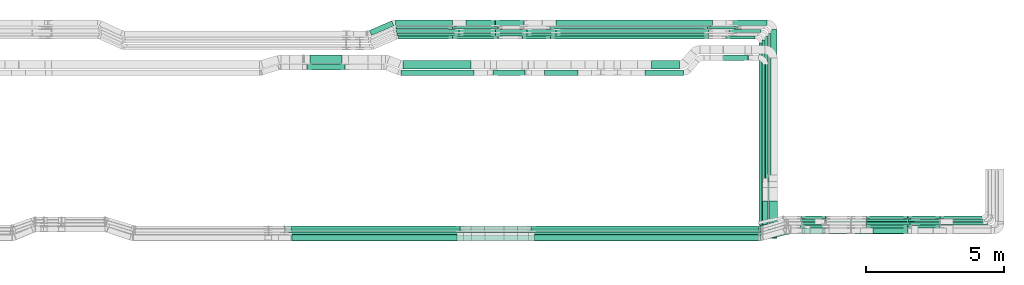
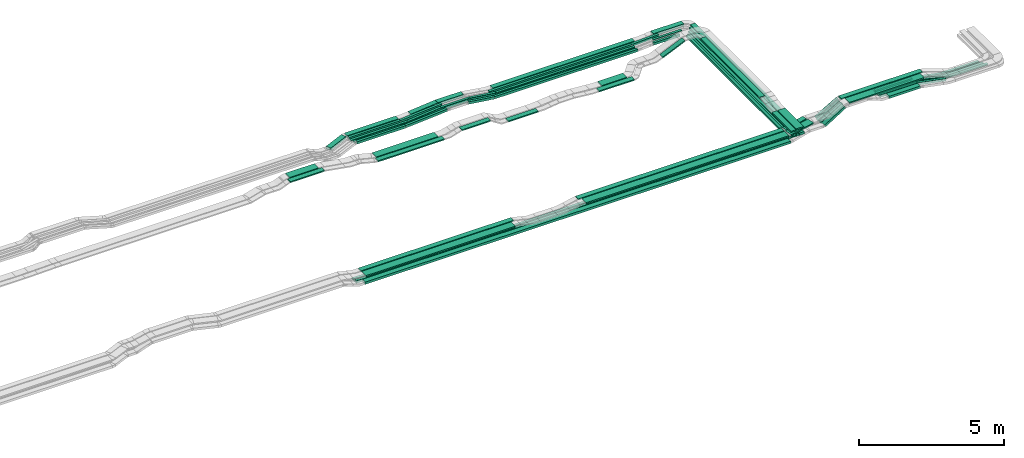
# One storey, part 2 of 28: 72 flow segments.
"""IFC2X3 building model written with IfcOpenShell, lengths in millimetres."""

from ifc_helpers import new_model, entity, si_unit, converted_unit, derived_unit, direction, frame, frame_2d, origin, origin_2d_with_axis, place, context, subcontext, project, spatial, rectangle, extrude, type_object, element, save


model = new_model("IFC2X3")

# Units and contexts
model_context = context("Model", 3, precision=0.01, world=origin(), true_north=direction((6.12303176911189e-17, 1.0)))
body_context = subcontext(model_context, "Body", "Model", "MODEL_VIEW")
ifc_project = project(units=[si_unit("LENGTHUNIT", "METRE", prefix="MILLI"), si_unit("AREAUNIT", "SQUARE_METRE"), si_unit("VOLUMEUNIT", "CUBIC_METRE"), converted_unit("PLANEANGLEUNIT", "DEGREE", entity("IfcRatioMeasure", 0.0174532925199433), si_unit("PLANEANGLEUNIT", "RADIAN"), dimensions=[0, 0, 0, 0, 0, 0, 0]), si_unit("MASSUNIT", "GRAM", prefix="KILO"), derived_unit("MASSDENSITYUNIT", [(si_unit("MASSUNIT", "GRAM", prefix="KILO"), 1), (si_unit("LENGTHUNIT", "METRE"), -3)]), derived_unit("MOMENTOFINERTIAUNIT", [(si_unit("LENGTHUNIT", "METRE"), 4)]), si_unit("TIMEUNIT", "SECOND"), si_unit("FREQUENCYUNIT", "HERTZ"), si_unit("THERMODYNAMICTEMPERATUREUNIT", "DEGREE_CELSIUS"), derived_unit("THERMALTRANSMITTANCEUNIT", [(si_unit("MASSUNIT", "GRAM", prefix="KILO"), 1), (si_unit("THERMODYNAMICTEMPERATUREUNIT", "KELVIN"), -1), (si_unit("TIMEUNIT", "SECOND"), -3)]), derived_unit("VOLUMETRICFLOWRATEUNIT", [(si_unit("LENGTHUNIT", "METRE"), 3), (si_unit("TIMEUNIT", "SECOND"), -1)]), derived_unit("MASSFLOWRATEUNIT", [(si_unit("MASSUNIT", "GRAM", prefix="KILO"), 1), (si_unit("TIMEUNIT", "SECOND"), -1)]), derived_unit("ROTATIONALFREQUENCYUNIT", [(si_unit("TIMEUNIT", "SECOND"), -1)]), si_unit("ELECTRICCURRENTUNIT", "AMPERE"), si_unit("ELECTRICVOLTAGEUNIT", "VOLT"), si_unit("POWERUNIT", "WATT"), si_unit("FORCEUNIT", "NEWTON", prefix="KILO"), si_unit("ILLUMINANCEUNIT", "LUX"), si_unit("LUMINOUSFLUXUNIT", "LUMEN"), si_unit("LUMINOUSINTENSITYUNIT", "CANDELA"), derived_unit("USERDEFINED", [(si_unit("MASSUNIT", "GRAM", prefix="KILO"), -1), (si_unit("LENGTHUNIT", "METRE"), -2), (si_unit("TIMEUNIT", "SECOND"), 3), (si_unit("LUMINOUSFLUXUNIT", "LUMEN"), 1)]), derived_unit("LINEARVELOCITYUNIT", [(si_unit("LENGTHUNIT", "METRE"), 1), (si_unit("TIMEUNIT", "SECOND"), -1)]), si_unit("PRESSUREUNIT", "PASCAL"), derived_unit("USERDEFINED", [(si_unit("LENGTHUNIT", "METRE"), -2), (si_unit("MASSUNIT", "GRAM", prefix="KILO"), 1), (si_unit("TIMEUNIT", "SECOND"), -2)]), derived_unit("LINEARFORCEUNIT", [(si_unit("MASSUNIT", "GRAM", prefix="KILO"), 1), (si_unit("LENGTHUNIT", "METRE"), 1), (si_unit("TIMEUNIT", "SECOND"), -2), (si_unit("LENGTHUNIT", "METRE"), -1)]), derived_unit("PLANARFORCEUNIT", [(si_unit("MASSUNIT", "GRAM", prefix="KILO"), 1), (si_unit("LENGTHUNIT", "METRE"), 1), (si_unit("TIMEUNIT", "SECOND"), -2), (si_unit("LENGTHUNIT", "METRE"), -2)])], contexts=[model_context])

# Site, building, storey
site_placement = place(None, origin())
site = spatial("IfcSite", under=ifc_project, at=site_placement, CompositionType="ELEMENT")
building_placement = place(site_placement, origin())
building = spatial("IfcBuilding", under=site, at=building_placement, CompositionType="ELEMENT")
storey_placement = place(building_placement, frame((0.0, 0.0, 15900.0)))
storey = spatial("IfcBuildingStorey", under=building, at=storey_placement, CompositionType="ELEMENT", Elevation=15900.0)

# Flow segments
cable_carrier_segment_type = type_object("IfcCableCarrierSegmentType", PredefinedType="CABLETRAYSEGMENT")
flow_segment_1_placement = place(storey_placement, frame((60126.08, 8284.99, 2660.0)))
element("IfcFlowSegment", 1, at=flow_segment_1_placement, inside=storey, type_object=cable_carrier_segment_type, context=body_context, shape_type="SweptSolid", body=[
    extrude(rectangle(XDim=7079.00000000001, YDim=99.9999999999946, at=origin_2d_with_axis()), frame((50.0, 3539.5, 0.0), z_axis=(0.0, 0.0, 1.0), x_axis=(0.0, -1.0, 0.0)), (0.0, 0.0, 1.0), 99.9999999999989),
])
flow_segment_2_placement = place(storey_placement, frame((60236.08, 8299.46, 2660.19)))
element("IfcFlowSegment", 2, at=flow_segment_2_placement, inside=storey, type_object=cable_carrier_segment_type, context=body_context, shape_type="SweptSolid", body=[
    extrude(rectangle(XDim=7179.00000000001, YDim=99.9999999999946, at=origin_2d_with_axis()), frame((50.0, 3589.5, 0.0), z_axis=(0.0, 0.0, 1.0), x_axis=(0.0, -1.0, 0.0)), (0.0, 0.0, 1.0), 50.0000000000016),
])
flow_segment_3_placement = place(storey_placement, frame((60346.08, 8299.99, 2660.2)))
element("IfcFlowSegment", 3, at=flow_segment_3_placement, inside=storey, type_object=cable_carrier_segment_type, context=body_context, shape_type="SweptSolid", body=[
    extrude(rectangle(XDim=7298.46409105725, YDim=99.9999999999946, at=origin_2d_with_axis()), frame((50.0, 3649.23, 0.0), z_axis=(0.0, 0.0, 1.0), x_axis=(0.0, -1.0, 0.0)), (0.0, 0.0, 1.0), 50.0000000000016),
])
flow_segment_4_placement = place(storey_placement, frame((43221.68, 8550.15, 2820.0)))
element("IfcFlowSegment", 4, at=flow_segment_4_placement, inside=storey, type_object=cable_carrier_segment_type, context=body_context, shape_type="SweptSolid", body=[
    extrude(rectangle(XDim=6093.02235435077, YDim=200.0, at=origin_2d_with_axis()), frame((3046.51, 100.0, 0.0), z_axis=(0.0, 0.0, 1.0), x_axis=(-1.0, 0.0, 0.0)), (0.0, 0.0, 1.0), 50.0000000000016),
])
flow_segment_5_placement = place(storey_placement, frame((43231.48, 8215.15, 2820.0)))
element("IfcFlowSegment", 5, at=flow_segment_5_placement, inside=storey, type_object=cable_carrier_segment_type, context=body_context, shape_type="SweptSolid", body=[
    extrude(rectangle(XDim=5963.81419063151, YDim=300.000000000001, at=origin_2d_with_axis()), frame((2981.91, 150.0, 0.0), z_axis=(0.0, 0.0, 1.0), x_axis=(-1.0, 0.0, 0.0)), (0.0, 0.0, 1.0), 50.0000000000016),
])
flow_segment_6_placement = place(storey_placement, frame((51889.38, 8550.15, 2820.0)))
element("IfcFlowSegment", 6, at=flow_segment_6_placement, inside=storey, type_object=cable_carrier_segment_type, context=body_context, shape_type="SweptSolid", body=[
    extrude(rectangle(XDim=8214.82266002888, YDim=200.0, at=origin_2d_with_axis()), frame((4107.41, 100.0, 0.0)), (0.0, 0.0, 1.0), 50.0000000000016),
])
flow_segment_7_placement = place(storey_placement, frame((52008.94, 8215.15, 2820.0)))
element("IfcFlowSegment", 7, at=flow_segment_7_placement, inside=storey, type_object=cable_carrier_segment_type, context=body_context, shape_type="SweptSolid", body=[
    extrude(rectangle(XDim=8089.55955573693, YDim=300.000000000001, at=origin_2d_with_axis()), frame((4044.78, 150.0, 0.0)), (0.0, 0.0, 1.0), 50.0000000000016),
])
flow_segment_8_placement = place(storey_placement, frame((42966.16, 8654.97, 2495.02)))
element("IfcFlowSegment", 8, at=flow_segment_8_placement, inside=storey, type_object=cable_carrier_segment_type, context=body_context, shape_type="SweptSolid", body=[
    extrude(rectangle(XDim=17232.0585205176, YDim=100.000000000001, at=origin_2d_with_axis()), frame((8616.03, 50.0, 0.0)), (0.0, 0.0, 1.0), 50.0000000000016),
])
flow_segment_9_placement = place(storey_placement, frame((42969.91, 8544.97, 2495.05)))
element("IfcFlowSegment", 9, at=flow_segment_9_placement, inside=storey, type_object=cable_carrier_segment_type, context=body_context, shape_type="SweptSolid", body=[
    extrude(rectangle(XDim=17228.3060029539, YDim=100.000000000001, at=origin_2d_with_axis()), frame((8614.15, 50.0, 0.0)), (0.0, 0.0, 1.0), 50.0000000000016),
])
flow_segment_10_placement = place(storey_placement, frame((42969.05, 8434.97, 2500.0)))
element("IfcFlowSegment", 10, at=flow_segment_10_placement, inside=storey, type_object=cable_carrier_segment_type, context=body_context, shape_type="SweptSolid", body=[
    extrude(rectangle(XDim=17229.1719303005, YDim=99.9999999999989, at=origin_2d_with_axis()), frame((8614.59, 50.0, 0.0)), (0.0, 0.0, 1.0), 99.9999999999989),
])
flow_segment_11_placement = place(storey_placement, frame((43203.46, 8224.97, 2500.0)))
element("IfcFlowSegment", 11, at=flow_segment_11_placement, inside=storey, type_object=cable_carrier_segment_type, context=body_context, shape_type="SweptSolid", body=[
    extrude(rectangle(XDim=16981.1662330708, YDim=200.0, at=origin_2d_with_axis()), frame((8490.58, 100.0, 0.0)), (0.0, 0.0, 1.0), 99.9999999999968),
])
flow_segment_12_placement = place(storey_placement, frame((60142.32, 8560.7, 2820.0)))
element("IfcFlowSegment", 12, at=flow_segment_12_placement, inside=storey, type_object=cable_carrier_segment_type, context=body_context, shape_type="SweptSolid", body=[
    extrude(rectangle(XDim=974.281376760203, YDim=200.000000000001, at=origin_2d_with_axis()), frame((496.88, 214.44, 0.0), z_axis=(0.0, 0.0, 1.0), x_axis=(-0.970529997992859, -0.240980337363821, 0.0)), (0.0, 0.0, 1.0), 50.0000000000016),
])
flow_segment_13_placement = place(storey_placement, frame((60133.72, 8226.57, 2820.0)))
element("IfcFlowSegment", 13, at=flow_segment_13_placement, inside=storey, type_object=cable_carrier_segment_type, context=body_context, shape_type="SweptSolid", body=[
    extrude(rectangle(XDim=1058.47458946237, YDim=300.000000000004, at=origin_2d_with_axis()), frame((549.32, 263.58, 0.0), z_axis=(0.0, 0.0, 1.0), x_axis=(-0.975122262229243, -0.221667710108901, 0.0)), (0.0, 0.0, 1.0), 50.0000000000016),
])
flow_segment_14_placement = place(storey_placement, frame((66666.27, 8904.97, 2595.87)))
element("IfcFlowSegment", 14, at=flow_segment_14_placement, inside=storey, type_object=cable_carrier_segment_type, context=body_context, shape_type="SweptSolid", body=[
    extrude(rectangle(XDim=1605.67956376244, YDim=99.9999999999989, at=origin_2d_with_axis()), frame((802.84, 50.0, 0.0), z_axis=(0.0, 0.0, 1.0), x_axis=(-1.0, 0.0, 0.0)), (0.0, 0.0, 1.0), 49.9999999999995),
])
flow_segment_15_placement = place(storey_placement, frame((62523.02, 8800.15, 3175.0)))
element("IfcFlowSegment", 15, at=flow_segment_15_placement, inside=storey, type_object=cable_carrier_segment_type, context=body_context, shape_type="SweptSolid", body=[
    extrude(rectangle(XDim=3245.01675058186, YDim=200.0, at=origin_2d_with_axis()), frame((1622.51, 100.0, 0.0)), (0.0, 0.0, 1.0), 49.9999999999995),
])
flow_segment_16_placement = place(storey_placement, frame((62649.81, 8465.15, 3175.0)))
element("IfcFlowSegment", 16, at=flow_segment_16_placement, inside=storey, type_object=cable_carrier_segment_type, context=body_context, shape_type="SweptSolid", body=[
    extrude(rectangle(XDim=2990.04095154965, YDim=299.999999999999, at=origin_2d_with_axis()), frame((1495.02, 150.0, 0.0)), (0.0, 0.0, 1.0), 50.0000000000016),
])
flow_segment_17_placement = place(storey_placement, frame((66660.32, 9014.97, 2595.87)))
element("IfcFlowSegment", 17, at=flow_segment_17_placement, inside=storey, type_object=cable_carrier_segment_type, context=body_context, shape_type="SweptSolid", body=[
    extrude(rectangle(XDim=1496.62032150407, YDim=99.9999999999989, at=origin_2d_with_axis()), frame((748.31, 50.0, 0.0), z_axis=(0.0, 0.0, 1.0), x_axis=(-1.0, 0.0, 0.0)), (0.0, 0.0, 1.0), 99.9999999999989),
])
flow_segment_18_placement = place(storey_placement, frame((66666.62, 8794.97, 2595.87)))
element("IfcFlowSegment", 18, at=flow_segment_18_placement, inside=storey, type_object=cable_carrier_segment_type, context=body_context, shape_type="SweptSolid", body=[
    extrude(rectangle(XDim=1715.31996800804, YDim=99.9999999999989, at=origin_2d_with_axis()), frame((857.66, 50.0, 0.0), z_axis=(0.0, 0.0, 1.0), x_axis=(-1.0, 0.0, 0.0)), (0.0, 0.0, 1.0), 50.0000000000016),
])
flow_segment_19_placement = place(storey_placement, frame((47238.09, 14435.03, 2650.0)))
element("IfcFlowSegment", 19, at=flow_segment_19_placement, inside=storey, type_object=cable_carrier_segment_type, context=body_context, shape_type="SweptSolid", body=[
    extrude(rectangle(XDim=2472.10759373964, YDim=300.000000000001, at=origin_2d_with_axis()), frame((1236.05, 150.0, 0.0)), (0.0, 0.0, 1.0), 50.0000000000016),
])
flow_segment_20_placement = place(storey_placement, frame((46977.55, 15999.99, 2635.0)))
element("IfcFlowSegment", 20, at=flow_segment_20_placement, inside=storey, type_object=cable_carrier_segment_type, context=body_context, shape_type="SweptSolid", body=[
    extrude(rectangle(XDim=2052.75232011683, YDim=199.999999999998, at=origin_2d_with_axis()), frame((1026.38, 100.0, 0.0)), (0.0, 0.0, 1.0), 99.9999999999989),
])
flow_segment_21_placement = place(storey_placement, frame((46985.56, 15869.99, 2635.0)))
element("IfcFlowSegment", 21, at=flow_segment_21_placement, inside=storey, type_object=cable_carrier_segment_type, context=body_context, shape_type="SweptSolid", body=[
    extrude(rectangle(XDim=2041.44898293753, YDim=99.9999999999989, at=origin_2d_with_axis()), frame((1020.72, 50.0, 0.0)), (0.0, 0.0, 1.0), 99.9999999999989),
])
flow_segment_22_placement = place(storey_placement, frame((46985.56, 15749.46, 2637.24)))
element("IfcFlowSegment", 22, at=flow_segment_22_placement, inside=storey, type_object=cable_carrier_segment_type, context=body_context, shape_type="SweptSolid", body=[
    extrude(rectangle(XDim=2290.66032248258, YDim=99.9999999999989, at=origin_2d_with_axis()), frame((1145.33, 50.0, 0.0)), (0.0, 0.0, 1.0), 50.0000000000016),
])
flow_segment_23_placement = place(storey_placement, frame((47028.23, 15629.46, 2637.24)))
element("IfcFlowSegment", 23, at=flow_segment_23_placement, inside=storey, type_object=cable_carrier_segment_type, context=body_context, shape_type="SweptSolid", body=[
    extrude(rectangle(XDim=2247.99500057377, YDim=99.9999999999989, at=origin_2d_with_axis()), frame((1124.0, 50.0, 0.0), z_axis=(0.0, 0.0, 1.0), x_axis=(-1.0, 0.0, 0.0)), (0.0, 0.0, 1.0), 50.0000000000016),
])
flow_segment_24_placement = place(storey_placement, frame((47088.23, 15514.99, 2634.95)))
element("IfcFlowSegment", 24, at=flow_segment_24_placement, inside=storey, type_object=cable_carrier_segment_type, context=body_context, shape_type="SweptSolid", body=[
    extrude(rectangle(XDim=1946.15966005004, YDim=99.9999999999989, at=origin_2d_with_axis()), frame((973.08, 50.0, 0.0), z_axis=(0.0, 0.0, 1.0), x_axis=(-1.0, 0.0, 0.0)), (0.0, 0.0, 1.0), 99.9999999999989),
])
flow_segment_25_placement = place(storey_placement, frame((50592.29, 15999.99, 2760.0)))
element("IfcFlowSegment", 25, at=flow_segment_25_placement, inside=storey, type_object=cable_carrier_segment_type, context=body_context, shape_type="SweptSolid", body=[
    extrude(rectangle(XDim=1023.30452444504, YDim=200.000000000002, at=origin_2d_with_axis()), frame((511.65, 100.0, 0.0), z_axis=(0.0, 0.0, 1.0), x_axis=(-1.0, 0.0, 0.0)), (0.0, 0.0, 1.0), 99.9999999999989),
])
flow_segment_26_placement = place(storey_placement, frame((50590.74, 15749.46, 2762.2)))
element("IfcFlowSegment", 26, at=flow_segment_26_placement, inside=storey, type_object=cable_carrier_segment_type, context=body_context, shape_type="SweptSolid", body=[
    extrude(rectangle(XDim=1131.59489516369, YDim=99.9999999999989, at=origin_2d_with_axis()), frame((565.8, 50.0, 0.0), z_axis=(0.0, 0.0, 1.0), x_axis=(-1.0, 0.0, 0.0)), (0.0, 0.0, 1.0), 50.0000000000016),
])
flow_segment_27_placement = place(storey_placement, frame((50590.74, 15629.46, 2762.2)))
element("IfcFlowSegment", 27, at=flow_segment_27_placement, inside=storey, type_object=cable_carrier_segment_type, context=body_context, shape_type="SweptSolid", body=[
    extrude(rectangle(XDim=1135.49890513971, YDim=99.9999999999989, at=origin_2d_with_axis()), frame((567.75, 50.0, 0.0), z_axis=(0.0, 0.0, 1.0), x_axis=(-1.0, 0.0, 0.0)), (0.0, 0.0, 1.0), 50.0000000000016),
])
flow_segment_28_placement = place(storey_placement, frame((52778.8, 15999.99, 2615.0)))
element("IfcFlowSegment", 28, at=flow_segment_28_placement, inside=storey, type_object=cable_carrier_segment_type, context=body_context, shape_type="SweptSolid", body=[
    extrude(rectangle(XDim=5664.14517649834, YDim=200.000000000002, at=origin_2d_with_axis()), frame((2832.07, 100.0, 0.0)), (0.0, 0.0, 1.0), 100.000000000001),
])
flow_segment_29_placement = place(storey_placement, frame((52567.15, 15869.99, 2615.0)))
element("IfcFlowSegment", 29, at=flow_segment_29_placement, inside=storey, type_object=cable_carrier_segment_type, context=body_context, shape_type="SweptSolid", body=[
    extrude(rectangle(XDim=5684.09323348246, YDim=99.9999999999989, at=origin_2d_with_axis()), frame((2842.05, 50.0, 0.0)), (0.0, 0.0, 1.0), 99.9999999999989),
])
flow_segment_30_placement = place(storey_placement, frame((52780.81, 15749.46, 2617.36)))
element("IfcFlowSegment", 30, at=flow_segment_30_placement, inside=storey, type_object=cable_carrier_segment_type, context=body_context, shape_type="SweptSolid", body=[
    extrude(rectangle(XDim=5535.15002954218, YDim=99.9999999999989, at=origin_2d_with_axis()), frame((2767.58, 50.0, 0.0)), (0.0, 0.0, 1.0), 50.0000000000016),
])
flow_segment_31_placement = place(storey_placement, frame((52780.81, 15629.46, 2617.36)))
element("IfcFlowSegment", 31, at=flow_segment_31_placement, inside=storey, type_object=cable_carrier_segment_type, context=body_context, shape_type="SweptSolid", body=[
    extrude(rectangle(XDim=5506.546574727, YDim=99.9999999999989, at=origin_2d_with_axis()), frame((2753.27, 50.0, 0.0)), (0.0, 0.0, 1.0), 50.0000000000016),
])
flow_segment_32_placement = place(storey_placement, frame((52583.2, 15514.99, 2617.03)))
element("IfcFlowSegment", 32, at=flow_segment_32_placement, inside=storey, type_object=cable_carrier_segment_type, context=body_context, shape_type="SweptSolid", body=[
    extrude(rectangle(XDim=5712.42683237125, YDim=99.9999999999989, at=origin_2d_with_axis()), frame((2856.21, 50.0, 0.0)), (0.0, 0.0, 1.0), 99.9999999999989),
])
flow_segment_33_placement = place(storey_placement, frame((49278.6, 15629.46, 2637.58)))
element("IfcFlowSegment", 33, at=flow_segment_33_placement, inside=storey, type_object=cable_carrier_segment_type, context=body_context, shape_type="SweptSolid", body=[
    extrude(rectangle(XDim=50.0000000000012, YDim=99.9999999999989, at=origin_2d_with_axis()), frame((2.37, 50.0, 24.89), z_axis=(0.995479968225896, 0.0, 0.0949717476988276), x_axis=(-0.0949717476988276, 0.0, 0.995479968225896)), (0.0, 0.0, 1.0), 1310.94723161525),
])
flow_segment_34_placement = place(storey_placement, frame((51728.78, 15629.46, 2618.01)))
element("IfcFlowSegment", 34, at=flow_segment_34_placement, inside=storey, type_object=cable_carrier_segment_type, context=body_context, shape_type="SweptSolid", body=[
    extrude(rectangle(XDim=50.0000000000022, YDim=99.9999999999989, at=origin_2d_with_axis()), frame((3.42, 50.0, 168.78), z_axis=(0.9905950071671, 0.0, -0.136826648631081), x_axis=(0.136826648631081, 0.0, 0.9905950071671)), (0.0, 0.0, 1.0), 1052.55355486941),
])
flow_segment_35_placement = place(storey_placement, frame((49278.6, 15749.46, 2637.58)))
element("IfcFlowSegment", 35, at=flow_segment_35_placement, inside=storey, type_object=cable_carrier_segment_type, context=body_context, shape_type="SweptSolid", body=[
    extrude(rectangle(XDim=50.0000000000012, YDim=99.9999999999989, at=origin_2d_with_axis()), frame((2.37, 50.0, 24.89), z_axis=(0.995479968225896, 0.0, 0.0949717476988276), x_axis=(-0.0949717476988276, 0.0, 0.995479968225896)), (0.0, 0.0, 1.0), 1310.94723161524),
])
flow_segment_36_placement = place(storey_placement, frame((51724.87, 15749.46, 2618.0)))
element("IfcFlowSegment", 36, at=flow_segment_36_placement, inside=storey, type_object=cable_carrier_segment_type, context=body_context, shape_type="SweptSolid", body=[
    extrude(rectangle(XDim=49.9999999999997, YDim=99.9999999999989, at=origin_2d_with_axis()), frame((3.41, 50.0, 168.79), z_axis=(0.990663695538499, 0.0, -0.136328435559149), x_axis=(0.136328435559149, 0.0, 0.990663695538499)), (0.0, 0.0, 1.0), 1056.44534930489),
])
flow_segment_37_placement = place(storey_placement, frame((49029.31, 15869.99, 2635.37)))
element("IfcFlowSegment", 37, at=flow_segment_37_placement, inside=storey, type_object=cable_carrier_segment_type, context=body_context, shape_type="SweptSolid", body=[
    extrude(rectangle(XDim=100.000000000002, YDim=99.9999999999989, at=frame_2d((0.0, 0.0), x_axis=(0.0, 1.0))), frame((3.75, 50.0, 49.86), z_axis=(0.997185843977158, 0.0, 0.0749692775179538), x_axis=(0.0, 1.0, 0.0)), (0.0, 0.0, 1.0), 1661.29562292556),
])
flow_segment_38_placement = place(storey_placement, frame((49520.8, 15999.99, 2658.8)))
element("IfcFlowSegment", 38, at=flow_segment_38_placement, inside=storey, type_object=cable_carrier_segment_type, context=body_context, shape_type="SweptSolid", body=[
    extrude(rectangle(XDim=99.9999999999997, YDim=199.999999999998, at=origin_2d_with_axis()), frame((4.75, 100.0, 49.77), z_axis=(0.995479968225879, 0.0, 0.0949717476990034), x_axis=(-0.0949717476990034, 0.0, 0.995479968225879)), (0.0, 0.0, 1.0), 1064.42423867442),
])
flow_segment_39_placement = place(storey_placement, frame((43889.72, 14635.03, 2835.0)))
element("IfcFlowSegment", 39, at=flow_segment_39_placement, inside=storey, type_object=cable_carrier_segment_type, context=body_context, shape_type="SweptSolid", body=[
    extrude(rectangle(XDim=1151.72101065198, YDim=300.000000000001, at=origin_2d_with_axis()), frame((575.86, 150.0, 0.0)), (0.0, 0.0, 1.0), 50.0000000000016),
])
flow_segment_40_placement = place(storey_placement, frame((43781.91, 14400.03, 2835.0)))
element("IfcFlowSegment", 40, at=flow_segment_40_placement, inside=storey, type_object=cable_carrier_segment_type, context=body_context, shape_type="SweptSolid", body=[
    extrude(rectangle(XDim=1369.74391930187, YDim=199.999999999998, at=origin_2d_with_axis()), frame((684.87, 100.0, 0.0)), (0.0, 0.0, 1.0), 50.0000000000016),
])
flow_segment_41_placement = place(storey_placement, frame((47168.73, 14200.03, 2650.0)))
element("IfcFlowSegment", 41, at=flow_segment_41_placement, inside=storey, type_object=cable_carrier_segment_type, context=body_context, shape_type="SweptSolid", body=[
    extrude(rectangle(XDim=2650.06252227778, YDim=200.000000000002, at=origin_2d_with_axis()), frame((1325.03, 100.0, 0.0)), (0.0, 0.0, 1.0), 50.0000000000016),
])
flow_segment_42_placement = place(storey_placement, frame((49036.68, 15514.99, 2635.32)))
element("IfcFlowSegment", 42, at=flow_segment_42_placement, inside=storey, type_object=cable_carrier_segment_type, context=body_context, shape_type="SweptSolid", body=[
    extrude(rectangle(XDim=99.9999999999993, YDim=99.9999999999989, at=origin_2d_with_axis()), frame((3.75, 50.0, 49.86), z_axis=(0.997183128198485, 0.0, 0.0750053920480587), x_axis=(-0.0750053920480587, 0.0, 0.997183128198485)), (0.0, 0.0, 1.0), 1655.9166479278),
])
flow_segment_43_placement = place(storey_placement, frame((51544.07, 15514.99, 2618.14)))
element("IfcFlowSegment", 43, at=flow_segment_43_placement, inside=storey, type_object=cable_carrier_segment_type, context=body_context, shape_type="SweptSolid", body=[
    extrude(rectangle(XDim=100.0, YDim=99.9999999999989, at=origin_2d_with_axis()), frame((6.84, 50.0, 190.82), z_axis=(0.990595007167099, 0.0, -0.136826648631087), x_axis=(0.136826648631087, 0.0, 0.990595007167099)), (0.0, 0.0, 1.0), 1032.6201995526),
])
flow_segment_44_placement = place(storey_placement, frame((46030.0, 15639.04, 2635.0)))
element("IfcFlowSegment", 44, at=flow_segment_44_placement, inside=storey, type_object=cable_carrier_segment_type, context=body_context, shape_type="SweptSolid", body=[
    extrude(rectangle(XDim=878.885872207849, YDim=199.999999999999, at=origin_2d_with_axis()), frame((443.09, 265.95, 0.0), z_axis=(0.0, 0.0, 1.0), x_axis=(-0.918134666973498, -0.396268511619916, 0.0)), (0.0, 0.0, 1.0), 99.9999999999989),
])
flow_segment_45_placement = place(storey_placement, frame((59189.53, 15999.99, 2660.0)))
element("IfcFlowSegment", 45, at=flow_segment_45_placement, inside=storey, type_object=cable_carrier_segment_type, context=body_context, shape_type="SweptSolid", body=[
    extrude(rectangle(XDim=1225.54994660658, YDim=200.000000000002, at=origin_2d_with_axis()), frame((612.77, 100.0, 0.0), z_axis=(0.0, 0.0, 1.0), x_axis=(-1.0, 0.0, 0.0)), (0.0, 0.0, 1.0), 99.9999999999989),
])
flow_segment_46_placement = place(storey_placement, frame((59037.94, 15749.46, 2660.2)))
element("IfcFlowSegment", 46, at=flow_segment_46_placement, inside=storey, type_object=cable_carrier_segment_type, context=body_context, shape_type="SweptSolid", body=[
    extrude(rectangle(XDim=1157.13606296418, YDim=99.9999999999989, at=origin_2d_with_axis()), frame((578.57, 50.0, 0.0), z_axis=(0.0, 0.0, 1.0), x_axis=(-1.0, 0.0, 0.0)), (0.0, 0.0, 1.0), 50.0000000000016),
])
flow_segment_47_placement = place(storey_placement, frame((58923.94, 15514.99, 2660.0)))
element("IfcFlowSegment", 47, at=flow_segment_47_placement, inside=storey, type_object=cable_carrier_segment_type, context=body_context, shape_type="SweptSolid", body=[
    extrude(rectangle(XDim=1051.13609183986, YDim=99.9999999999989, at=origin_2d_with_axis()), frame((525.57, 50.0, 0.0), z_axis=(0.0, 0.0, 1.0), x_axis=(-1.0, 0.0, 0.0)), (0.0, 0.0, 1.0), 99.9999999999989),
])
flow_segment_48_placement = place(storey_placement, frame((58253.41, 15869.99, 2615.13)))
element("IfcFlowSegment", 48, at=flow_segment_48_placement, inside=storey, type_object=cable_carrier_segment_type, context=body_context, shape_type="SweptSolid", body=[
    extrude(rectangle(XDim=99.9999999999985, YDim=99.9999999999989, at=frame_2d((0.0, 0.0), x_axis=(0.0, 1.0))), frame((2.07, 50.0, 49.96), z_axis=(0.999143050018217, 0.0, 0.0413904046886989), x_axis=(0.0, 1.0, 0.0)), (0.0, 0.0, 1.0), 1082.97246499199),
])
flow_segment_49_placement = place(storey_placement, frame((50520.15, 14200.03, 2790.0)))
element("IfcFlowSegment", 49, at=flow_segment_49_placement, inside=storey, type_object=cable_carrier_segment_type, context=body_context, shape_type="SweptSolid", body=[
    extrude(rectangle(XDim=1135.94756189123, YDim=200.000000000002, at=origin_2d_with_axis()), frame((567.97, 100.0, 0.0), z_axis=(0.0, 0.0, 1.0), x_axis=(-1.0, 0.0, 0.0)), (0.0, 0.0, 1.0), 50.0000000000016),
])
flow_segment_50_placement = place(storey_placement, frame((52362.8, 14200.03, 2510.0)))
element("IfcFlowSegment", 50, at=flow_segment_50_placement, inside=storey, type_object=cable_carrier_segment_type, context=body_context, shape_type="SweptSolid", body=[
    extrude(rectangle(XDim=1206.14612446976, YDim=200.000000000002, at=origin_2d_with_axis()), frame((603.07, 100.0, 0.0)), (0.0, 0.0, 1.0), 50.0000000000016),
])
flow_segment_51_placement = place(storey_placement, frame((56227.79, 14435.03, 2510.0)))
element("IfcFlowSegment", 51, at=flow_segment_51_placement, inside=storey, type_object=cable_carrier_segment_type, context=body_context, shape_type="SweptSolid", body=[
    extrude(rectangle(XDim=1007.78319978753, YDim=300.000000000001, at=origin_2d_with_axis()), frame((503.89, 150.0, 0.0)), (0.0, 0.0, 1.0), 50.0000000000038),
])
flow_segment_52_placement = place(storey_placement, frame((55987.76, 14200.03, 2510.0)))
element("IfcFlowSegment", 52, at=flow_segment_52_placement, inside=storey, type_object=cable_carrier_segment_type, context=body_context, shape_type="SweptSolid", body=[
    extrude(rectangle(XDim=1407.59439067443, YDim=200.000000000002, at=origin_2d_with_axis()), frame((703.8, 100.0, 0.0)), (0.0, 0.0, 1.0), 50.0000000000016),
])
flow_segment_53_placement = place(storey_placement, frame((58823.1, 14740.03, 2615.54)))
element("IfcFlowSegment", 53, at=flow_segment_53_placement, inside=storey, type_object=cable_carrier_segment_type, context=body_context, shape_type="SweptSolid", body=[
    extrude(rectangle(XDim=50.0000000000009, YDim=199.999999999998, at=frame_2d((0.0, 0.0), x_axis=(0.0, 1.0))), frame((10.1, 100.0, 22.87), z_axis=(0.914695360334444, 0.0, 0.404144030987273), x_axis=(0.0, 1.0, 0.0)), (0.0, 0.0, 1.0), 974.200244285783),
])
flow_segment_54_placement = place(storey_placement, frame((60456.08, 8299.99, 2660.0)))
element("IfcFlowSegment", 54, at=flow_segment_54_placement, inside=storey, type_object=cable_carrier_segment_type, context=body_context, shape_type="SweptSolid", body=[
    extrude(rectangle(XDim=7419.00000000005, YDim=99.9999999999946, at=origin_2d_with_axis()), frame((50.0, 3709.5, 0.0), z_axis=(0.0, 0.0, 1.0), x_axis=(0.0, -1.0, 0.0)), (0.0, 0.0, 1.0), 99.9999999999989),
])
flow_segment_55_placement = place(storey_placement, frame((60566.08, 8299.99, 2660.0)))
element("IfcFlowSegment", 55, at=flow_segment_55_placement, inside=storey, type_object=cable_carrier_segment_type, context=body_context, shape_type="SweptSolid", body=[
    extrude(rectangle(XDim=7549.00000000001, YDim=200.000000000007, at=origin_2d_with_axis()), frame((100.0, 3774.5, 0.0), z_axis=(0.0, 0.0, 1.0), x_axis=(0.0, -1.0, 0.0)), (0.0, 0.0, 1.0), 99.9999999999989),
])
flow_segment_56_placement = place(storey_placement, frame((60246.82, 8323.62, 2880.0)))
element("IfcFlowSegment", 56, at=flow_segment_56_placement, inside=storey, type_object=cable_carrier_segment_type, context=body_context, shape_type="SweptSolid", body=[
    extrude(rectangle(XDim=1329.66833027692, YDim=200.000000000007, at=origin_2d_with_axis()), frame((100.0, 664.83, 0.0), z_axis=(0.0, 0.0, 1.0), x_axis=(0.0, -1.0, 0.0)), (0.0, 0.0, 1.0), 50.0000000000016),
])
flow_segment_57_placement = place(storey_placement, frame((60480.82, 8363.62, 2880.0)))
element("IfcFlowSegment", 57, at=flow_segment_57_placement, inside=storey, type_object=cable_carrier_segment_type, context=body_context, shape_type="SweptSolid", body=[
    extrude(rectangle(XDim=1289.66833027692, YDim=300.000000000001, at=origin_2d_with_axis()), frame((150.0, 644.83, 0.0), z_axis=(0.0, 0.0, 1.0), x_axis=(0.0, -1.0, 0.0)), (0.0, 0.0, 1.0), 50.0000000000016),
])
flow_segment_58_placement = place(storey_placement, frame((60246.82, 10481.67, 3010.0)))
element("IfcFlowSegment", 58, at=flow_segment_58_placement, inside=storey, type_object=cable_carrier_segment_type, context=body_context, shape_type="SweptSolid", body=[
    extrude(rectangle(XDim=4107.35377064785, YDim=200.000000000007, at=origin_2d_with_axis()), frame((100.0, 2053.68, 0.0), z_axis=(0.0, 0.0, 1.0), x_axis=(0.0, -1.0, 0.0)), (0.0, 0.0, 1.0), 50.0000000000016),
])
flow_segment_59_placement = place(storey_placement, frame((61669.37, 8474.97, 2516.63)))
element("IfcFlowSegment", 59, at=flow_segment_59_placement, inside=storey, type_object=cable_carrier_segment_type, context=body_context, shape_type="SweptSolid", body=[
    extrude(rectangle(XDim=100.000000000002, YDim=200.0, at=origin_2d_with_axis()), frame((26.72, 100.0, 42.26), z_axis=(0.845240241928734, 0.0, 0.534386501910608), x_axis=(-0.534386501910608, 0.0, 0.845240241928734)), (0.0, 0.0, 1.0), 949.97195444437),
])
flow_segment_60_placement = place(storey_placement, frame((61620.42, 8684.97, 2514.45)))
element("IfcFlowSegment", 60, at=flow_segment_60_placement, inside=storey, type_object=cable_carrier_segment_type, context=body_context, shape_type="SweptSolid", body=[
    extrude(rectangle(XDim=99.9999999999952, YDim=100.000000000001, at=origin_2d_with_axis()), frame((25.01, 50.0, 43.29), z_axis=(0.865893399879649, 0.0, 0.500228567801622), x_axis=(-0.500228567801622, 0.0, 0.865893399879649)), (0.0, 0.0, 1.0), 1019.43607262713),
])
flow_segment_61_placement = place(storey_placement, frame((61680.98, 8794.97, 2511.1)))
element("IfcFlowSegment", 61, at=flow_segment_61_placement, inside=storey, type_object=cable_carrier_segment_type, context=body_context, shape_type="SweptSolid", body=[
    extrude(rectangle(XDim=49.9999999999965, YDim=100.000000000001, at=origin_2d_with_axis()), frame((13.09, 50.0, 21.3), z_axis=(0.851940405089958, 0.0, 0.523638755417471), x_axis=(-0.523638755417471, 0.0, 0.851940405089958)), (0.0, 0.0, 1.0), 975.15520337308),
])
flow_segment_62_placement = place(storey_placement, frame((61642.55, 8904.97, 2505.41)))
element("IfcFlowSegment", 62, at=flow_segment_62_placement, inside=storey, type_object=cable_carrier_segment_type, context=body_context, shape_type="SweptSolid", body=[
    extrude(rectangle(XDim=49.9999999999998, YDim=100.000000000001, at=origin_2d_with_axis()), frame((12.69, 50.0, 21.54), z_axis=(0.861478647120952, 0.0, 0.507793797278634), x_axis=(-0.507793797278634, 0.0, 0.861478647120952)), (0.0, 0.0, 1.0), 1017.26176000681),
])
flow_segment_63_placement = place(storey_placement, frame((61634.25, 9014.97, 2514.45)))
element("IfcFlowSegment", 63, at=flow_segment_63_placement, inside=storey, type_object=cable_carrier_segment_type, context=body_context, shape_type="SweptSolid", body=[
    extrude(rectangle(XDim=99.999999999997, YDim=100.000000000001, at=origin_2d_with_axis()), frame((25.01, 50.0, 43.29), z_axis=(0.865893399879655, 0.0, 0.500228567801613), x_axis=(-0.500228567801613, 0.0, 0.865893399879655)), (0.0, 0.0, 1.0), 1019.43607262712),
])
flow_segment_64_placement = place(storey_placement, frame((64002.26, 8904.97, 2818.48)))
element("IfcFlowSegment", 64, at=flow_segment_64_placement, inside=storey, type_object=cable_carrier_segment_type, context=body_context, shape_type="SweptSolid", body=[
    extrude(rectangle(XDim=1481.27373216724, YDim=100.000000000001, at=origin_2d_with_axis()), frame((740.64, 50.0, 0.0)), (0.0, 0.0, 1.0), 50.0000000000016),
])
flow_segment_65_placement = place(storey_placement, frame((64002.19, 8794.97, 2818.48)))
element("IfcFlowSegment", 65, at=flow_segment_65_placement, inside=storey, type_object=cable_carrier_segment_type, context=body_context, shape_type="SweptSolid", body=[
    extrude(rectangle(XDim=1565.90224789294, YDim=99.9999999999989, at=origin_2d_with_axis()), frame((782.95, 50.0, 0.0)), (0.0, 0.0, 1.0), 50.0000000000016),
])
flow_segment_66_placement = place(storey_placement, frame((64008.23, 8684.97, 2818.48)))
element("IfcFlowSegment", 66, at=flow_segment_66_placement, inside=storey, type_object=cable_carrier_segment_type, context=body_context, shape_type="SweptSolid", body=[
    extrude(rectangle(XDim=1481.28976278367, YDim=100.000000000001, at=origin_2d_with_axis()), frame((740.64, 50.0, 0.0)), (0.0, 0.0, 1.0), 99.9999999999989),
])
flow_segment_67_placement = place(storey_placement, frame((64246.75, 8474.97, 2818.48)))
element("IfcFlowSegment", 67, at=flow_segment_67_placement, inside=storey, type_object=cable_carrier_segment_type, context=body_context, shape_type="SweptSolid", body=[
    extrude(rectangle(XDim=1242.77534999253, YDim=200.0, at=origin_2d_with_axis()), frame((621.39, 100.0, 0.0)), (0.0, 0.0, 1.0), 99.9999999999989),
])
flow_segment_68_placement = place(storey_placement, frame((64001.68, 9014.97, 2818.48)))
element("IfcFlowSegment", 68, at=flow_segment_68_placement, inside=storey, type_object=cable_carrier_segment_type, context=body_context, shape_type="SweptSolid", body=[
    extrude(rectangle(XDim=1487.84310164632, YDim=100.000000000001, at=origin_2d_with_axis()), frame((743.92, 50.0, 0.0)), (0.0, 0.0, 1.0), 99.9999999999989),
])
flow_segment_69_placement = place(storey_placement, frame((65492.26, 8684.97, 2597.93)))
element("IfcFlowSegment", 69, at=flow_segment_69_placement, inside=storey, type_object=cable_carrier_segment_type, context=body_context, shape_type="SweptSolid", body=[
    extrude(rectangle(XDim=100.000000000002, YDim=100.000000000001, at=origin_2d_with_axis()), frame((9.43, 50.0, 269.39), z_axis=(0.982035536310349, 0.0, -0.188696066264366), x_axis=(0.188696066264366, 0.0, 0.982035536310349)), (0.0, 0.0, 1.0), 1167.42936222278),
])
flow_segment_70_placement = place(storey_placement, frame((65573.1, 8794.97, 2597.39)))
element("IfcFlowSegment", 70, at=flow_segment_70_placement, inside=storey, type_object=cable_carrier_segment_type, context=body_context, shape_type="SweptSolid", body=[
    extrude(rectangle(XDim=50.0000000000034, YDim=99.9999999999989, at=origin_2d_with_axis()), frame((5.01, 50.0, 245.07), z_axis=(0.979719044774343, 0.0, -0.200376129582467), x_axis=(0.200376129582467, 0.0, 0.979719044774343)), (0.0, 0.0, 1.0), 1100.82367316467),
])
flow_segment_71_placement = place(storey_placement, frame((65488.19, 8904.97, 2597.19)))
element("IfcFlowSegment", 71, at=flow_segment_71_placement, inside=storey, type_object=cable_carrier_segment_type, context=body_context, shape_type="SweptSolid", body=[
    extrude(rectangle(XDim=49.9999999999982, YDim=100.000000000001, at=origin_2d_with_axis()), frame((4.66, 50.0, 245.42), z_axis=(0.982474464164288, 0.0, -0.186397229767761), x_axis=(0.186397229767761, 0.0, 0.982474464164288)), (0.0, 0.0, 1.0), 1184.85842947056),
])
flow_segment_72_placement = place(storey_placement, frame((65492.26, 9014.97, 2597.93)))
element("IfcFlowSegment", 72, at=flow_segment_72_placement, inside=storey, type_object=cable_carrier_segment_type, context=body_context, shape_type="SweptSolid", body=[
    extrude(rectangle(XDim=100.000000000002, YDim=99.9999999999989, at=origin_2d_with_axis()), frame((9.43, 50.0, 269.39), z_axis=(0.982035536310349, 0.0, -0.188696066264366), x_axis=(0.188696066264366, 0.0, 0.982035536310349)), (0.0, 0.0, 1.0), 1167.42936222277),
])

save(model, "model.ifc")
